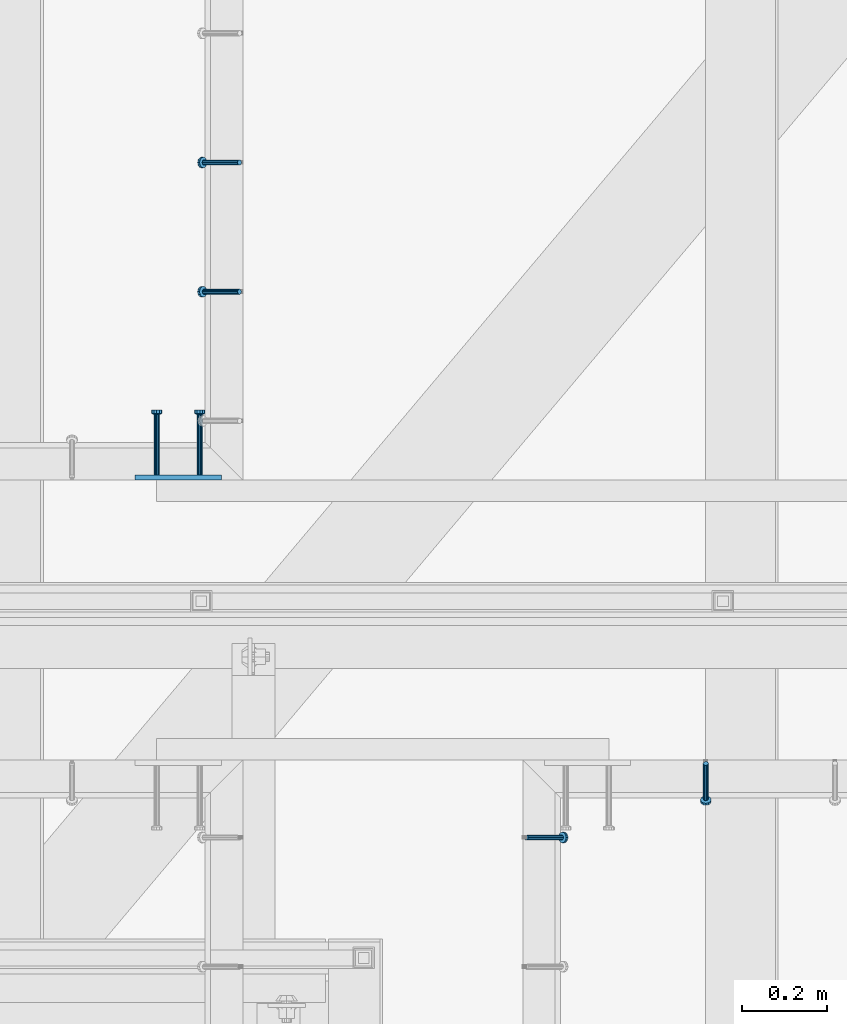
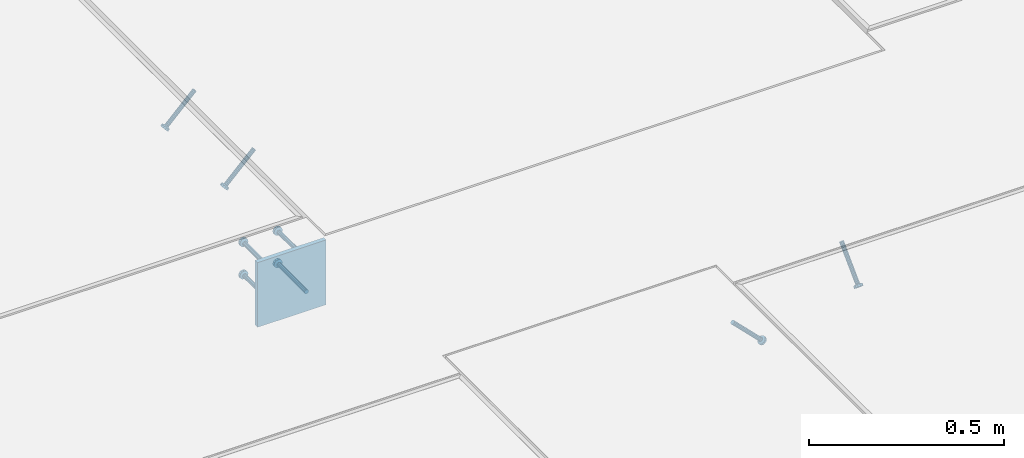
# One storey, part 2122 of 3843: 5 beams, 4 members, 4 elements without a shape of their own.
"""IFC2X3 building model written with IfcOpenShell, lengths in millimetres."""

from ifc_helpers import new_model, si_unit, frame, origin_with_axes, place, context, subcontext, project, spatial, faceted_brep, material, type_object, element, aggregate, save


model = new_model("IFC2X3")

# Units and contexts
model_context = context("Model", 3, precision=1e-05, world=origin_with_axes())
body_context = subcontext(model_context, "Body", "Model", "MODEL_VIEW")
ifc_project = project(units=[si_unit("LENGTHUNIT", "METRE", prefix="MILLI"), si_unit("AREAUNIT", "SQUARE_METRE"), si_unit("VOLUMEUNIT", "CUBIC_METRE"), si_unit("MASSUNIT", "GRAM", prefix="KILO"), si_unit("TIMEUNIT", "SECOND"), si_unit("PLANEANGLEUNIT", "RADIAN"), si_unit("SOLIDANGLEUNIT", "STERADIAN"), si_unit("THERMODYNAMICTEMPERATUREUNIT", "DEGREE_CELSIUS"), si_unit("LUMINOUSINTENSITYUNIT", "LUMEN")], contexts=[model_context])

# Site, building, storey
site_placement = place(None, origin_with_axes())
site = spatial("IfcSite", under=ifc_project, at=site_placement, CompositionType="ELEMENT")
building_placement = place(site_placement, origin_with_axes())
building = spatial("IfcBuilding", under=site, at=building_placement, Name="Undefined", CompositionType="ELEMENT")
storey_placement = place(building_placement, origin_with_axes())
storey = spatial("IfcBuildingStorey", under=building, at=storey_placement, Name="Undefined", CompositionType="ELEMENT", Elevation=0.0)

# Assembly, member
assembly_1_placement = place(storey_placement, origin_with_axes())
assembly_1 = element("IfcElementAssembly", 1, at=assembly_1_placement, inside=storey, Name="EMBED_ANGLE", AssemblyPlace="NOTDEFINED", PredefinedType="RIGID_FRAME")
ifc_material_1 = material(Name="STEEL/A108")
member_type = type_object("IfcMemberType", PredefinedType="NOTDEFINED")
member_1_placement = place(assembly_1_placement, frame((51951.6995146959, 27986.0374966989, 30446.6625), z_axis=(0.0, 1.0, 0.0), x_axis=(0.707106781186548, 0.0, -0.707106781186548)))
member_1 = element("IfcMember", 2, at=member_1_placement, type_object=member_type, material=ifc_material_1, Name="HEADED STUD ANCHOR", context=body_context, shape_type="Brep", body=[
    faceted_brep([(7.27595761418343e-12, -3.18000006675175, 5.5), (0.0, -5.49999999998363, 3.1800000667572), (118.110000000976, -5.49999999999091, 3.1800000667572), (118.110000000983, -3.18000006675175, 5.5), (0.0, -6.3499999046162, 0.0), (118.110000000968, -6.34999990461256, 0.0), (0.0, -5.49999999998363, -3.1800000667572), (118.110000000976, -5.49999999999091, -3.1800000667572), (7.27595761418343e-12, -3.18000006675175, -5.5), (118.110000000983, -3.18000006675175, -5.5), (7.27595761418343e-12, -1.81898940354586e-12, -6.34999990463257), (118.110000000968, -1.81898940354586e-12, -6.34999990463257), (0.0, 3.18000006675175, -5.5), (118.110000000968, 3.18000006674811, -5.5), (7.27595761418343e-12, 5.49999999998363, -3.1800000667572), (118.110000000983, 5.49999999998363, -3.1800000667572), (7.27595761418343e-12, 6.3499999046162, 0.0), (118.110000000976, 6.34999990461256, 0.0), (7.27595761418343e-12, 5.49999999998363, 3.1800000667572), (118.110000000983, 5.49999999998363, 3.1800000667572), (0.0, 3.18000006675175, 5.5), (118.110000000968, 3.18000006674811, 5.5), (7.27595761418343e-12, -1.81898940354586e-12, 6.34999990463257), (118.110000000968, -1.81898940354586e-12, 6.34999990463257), (120.650000000991, -10.9899997710909, 6.34999990463257), (120.650000000998, -6.34000015257152, 10.9899997711182), (120.650000000991, -12.6999998092379, 0.0), (120.650000000991, -10.9899997710909, -6.34999990463257), (120.650000000998, -6.34000015257152, -10.9899997711182), (120.650000000991, -1.81898940354586e-12, -12.6899995803833), (120.650000000991, 6.34000015257152, -10.9899997711182), (120.650000000998, 10.9899997710909, -6.34999990463257), (120.650000000991, 12.6999998092342, 0.0), (120.650000000998, 10.9899997710909, 6.34999990463257), (120.650000000991, 6.34000015257152, 10.9899997711182), (120.650000000991, -1.81898940354586e-12, 12.6899995803833), (127.000000001048, -10.9899997710945, 6.34999990463257), (127.000000001048, -6.34000015257152, 10.9899997711182), (127.000000001048, -12.6999998092342, 0.0), (127.000000001048, -10.9899997710945, -6.34999990463257), (127.000000001048, -6.34000015257152, -10.9899997711182), (127.000000001048, 1.81898940354586e-12, -12.6899995803833), (127.000000001048, 6.34000015256788, -10.9899997711182), (127.000000001048, 10.9899997710909, -6.34999990463257), (127.000000001048, 12.6999998092379, 0.0), (127.000000001048, 10.9899997710909, 6.34999990463257), (127.000000001048, 6.34000015256788, 10.9899997711182), (127.000000001048, 1.81898940354586e-12, 12.6899995803833)], [[[0, 1, 2, 3]], [[1, 4, 5, 2]], [[4, 6, 7, 5]], [[6, 8, 9, 7]], [[8, 10, 11, 9]], [[10, 12, 13, 11]], [[12, 14, 15, 13]], [[14, 16, 17, 15]], [[16, 18, 19, 17]], [[18, 20, 21, 19]], [[20, 22, 23, 21]], [[22, 0, 3, 23]], [[22, 20, 18, 16, 14, 12, 10, 8, 6, 4, 1, 0]], [[3, 2, 24, 25]], [[2, 5, 26, 24]], [[5, 7, 27, 26]], [[7, 9, 28, 27]], [[9, 11, 29, 28]], [[11, 13, 30, 29]], [[13, 15, 31, 30]], [[15, 17, 32, 31]], [[17, 19, 33, 32]], [[19, 21, 34, 33]], [[21, 23, 35, 34]], [[23, 3, 25, 35]], [[25, 24, 36, 37]], [[24, 26, 38, 36]], [[26, 27, 39, 38]], [[27, 28, 40, 39]], [[28, 29, 41, 40]], [[29, 30, 42, 41]], [[30, 31, 43, 42]], [[31, 32, 44, 43]], [[32, 33, 45, 44]], [[33, 34, 46, 45]], [[34, 35, 47, 46]], [[35, 25, 37, 47]], [[38, 39, 40, 41, 42, 43, 44, 45, 46, 47, 37, 36]]]),
])
aggregate(assembly_1, [member_1])

assembly_2_placement = place(storey_placement, origin_with_axes())
assembly_2 = element("IfcElementAssembly", 3, at=assembly_2_placement, inside=storey, Name="EMBED_ANGLE", AssemblyPlace="NOTDEFINED", PredefinedType="RIGID_FRAME")
member_2_placement = place(assembly_2_placement, frame((52375.5623417968, 28160.6624984764, 30446.6625), z_axis=(-1.0, 0.0, 0.0), x_axis=(0.0, -0.707106781186548, -0.707106781186548)))
member_2 = element("IfcMember", 4, at=member_2_placement, type_object=member_type, material=ifc_material_1, Name="HEADED STUD ANCHOR", context=body_context, shape_type="Brep", body=[
    faceted_brep([(7.27595761418343e-12, -3.18000006675175, 5.5), (0.0, -5.49999999998363, 3.1800000667572), (118.110000000976, -5.49999999999091, 3.1800000667572), (118.110000000983, -3.18000006675175, 5.5), (0.0, -6.3499999046162, 0.0), (118.110000000968, -6.34999990461256, 0.0), (0.0, -5.49999999998363, -3.1800000667572), (118.110000000976, -5.49999999999091, -3.1800000667572), (7.27595761418343e-12, -3.18000006675175, -5.5), (118.110000000983, -3.18000006675175, -5.5), (7.27595761418343e-12, -1.81898940354586e-12, -6.34999990463257), (118.110000000968, -1.81898940354586e-12, -6.34999990463257), (0.0, 3.18000006675175, -5.5), (118.110000000968, 3.18000006674811, -5.5), (7.27595761418343e-12, 5.49999999998363, -3.1800000667572), (118.110000000983, 5.49999999998363, -3.1800000667572), (7.27595761418343e-12, 6.3499999046162, 0.0), (118.110000000976, 6.34999990461256, 0.0), (7.27595761418343e-12, 5.49999999998363, 3.1800000667572), (118.110000000983, 5.49999999998363, 3.1800000667572), (0.0, 3.18000006675175, 5.5), (118.110000000968, 3.18000006674811, 5.5), (7.27595761418343e-12, -1.81898940354586e-12, 6.34999990463257), (118.110000000968, -1.81898940354586e-12, 6.34999990463257), (120.650000000991, -10.9899997710909, 6.34999990463257), (120.650000000998, -6.34000015257152, 10.9899997711182), (120.650000000991, -12.6999998092379, 0.0), (120.650000000991, -10.9899997710909, -6.34999990463257), (120.650000000998, -6.34000015257152, -10.9899997711182), (120.650000000991, -1.81898940354586e-12, -12.6899995803833), (120.650000000991, 6.34000015257152, -10.9899997711182), (120.650000000998, 10.9899997710909, -6.34999990463257), (120.650000000991, 12.6999998092342, 0.0), (120.650000000998, 10.9899997710909, 6.34999990463257), (120.650000000991, 6.34000015257152, 10.9899997711182), (120.650000000991, -1.81898940354586e-12, 12.6899995803833), (127.000000001048, -10.9899997710945, 6.34999990463257), (127.000000001048, -6.34000015257152, 10.9899997711182), (127.000000001048, -12.6999998092342, 0.0), (127.000000001048, -10.9899997710945, -6.34999990463257), (127.000000001048, -6.34000015257152, -10.9899997711182), (127.000000001048, 1.81898940354586e-12, -12.6899995803833), (127.000000001048, 6.34000015256788, -10.9899997711182), (127.000000001048, 10.9899997710909, -6.34999990463257), (127.000000001048, 12.6999998092379, 0.0), (127.000000001048, 10.9899997710909, 6.34999990463257), (127.000000001048, 6.34000015256788, 10.9899997711182), (127.000000001048, 1.81898940354586e-12, 12.6899995803833)], [[[0, 1, 2, 3]], [[1, 4, 5, 2]], [[4, 6, 7, 5]], [[6, 8, 9, 7]], [[8, 10, 11, 9]], [[10, 12, 13, 11]], [[12, 14, 15, 13]], [[14, 16, 17, 15]], [[16, 18, 19, 17]], [[18, 20, 21, 19]], [[20, 22, 23, 21]], [[22, 0, 3, 23]], [[22, 20, 18, 16, 14, 12, 10, 8, 6, 4, 1, 0]], [[3, 2, 24, 25]], [[2, 5, 26, 24]], [[5, 7, 27, 26]], [[7, 9, 28, 27]], [[9, 11, 29, 28]], [[11, 13, 30, 29]], [[13, 15, 31, 30]], [[15, 17, 32, 31]], [[17, 19, 33, 32]], [[19, 21, 34, 33]], [[21, 23, 35, 34]], [[23, 3, 25, 35]], [[25, 24, 36, 37]], [[24, 26, 38, 36]], [[26, 27, 39, 38]], [[27, 28, 40, 39]], [[28, 29, 41, 40]], [[29, 30, 42, 41]], [[30, 31, 43, 42]], [[31, 32, 44, 43]], [[32, 33, 45, 44]], [[33, 34, 46, 45]], [[34, 35, 47, 46]], [[35, 25, 37, 47]], [[38, 39, 40, 41, 42, 43, 44, 45, 46, 47, 37, 36]]]),
])
aggregate(assembly_2, [member_2])

# Assembly, members
assembly_3_placement = place(storey_placement, origin_with_axes())
assembly_3 = element("IfcElementAssembly", 5, at=assembly_3_placement, inside=storey, Name="EMBED_ANGLE", AssemblyPlace="NOTDEFINED", PredefinedType="RIGID_FRAME")
member_3_placement = place(assembly_3_placement, frame((51275.424484375, 29273.626609375, 30446.6625), z_axis=(0.0, 1.0, 0.0), x_axis=(-0.707106781186548, 0.0, -0.707106781186548)))
member_3 = element("IfcMember", 6, at=member_3_placement, type_object=member_type, material=ifc_material_1, Name="HEADED STUD ANCHOR", context=body_context, shape_type="Brep", body=[
    faceted_brep([(7.27595761418343e-12, -3.18000006675175, 5.5), (0.0, -5.49999999998363, 3.1800000667572), (118.110000000976, -5.49999999999091, 3.1800000667572), (118.110000000983, -3.18000006675175, 5.5), (0.0, -6.3499999046162, 0.0), (118.110000000968, -6.34999990461256, 0.0), (0.0, -5.49999999998363, -3.1800000667572), (118.110000000976, -5.49999999999091, -3.1800000667572), (7.27595761418343e-12, -3.18000006675175, -5.5), (118.110000000983, -3.18000006675175, -5.5), (7.27595761418343e-12, -1.81898940354586e-12, -6.34999990463257), (118.110000000968, -1.81898940354586e-12, -6.34999990463257), (0.0, 3.18000006675175, -5.5), (118.110000000968, 3.18000006674811, -5.5), (7.27595761418343e-12, 5.49999999998363, -3.1800000667572), (118.110000000983, 5.49999999998363, -3.1800000667572), (7.27595761418343e-12, 6.3499999046162, 0.0), (118.110000000976, 6.34999990461256, 0.0), (7.27595761418343e-12, 5.49999999998363, 3.1800000667572), (118.110000000983, 5.49999999998363, 3.1800000667572), (0.0, 3.18000006675175, 5.5), (118.110000000968, 3.18000006674811, 5.5), (7.27595761418343e-12, -1.81898940354586e-12, 6.34999990463257), (118.110000000968, -1.81898940354586e-12, 6.34999990463257), (120.650000000991, -10.9899997710909, 6.34999990463257), (120.650000000998, -6.34000015257152, 10.9899997711182), (120.650000000991, -12.6999998092379, 0.0), (120.650000000991, -10.9899997710909, -6.34999990463257), (120.650000000998, -6.34000015257152, -10.9899997711182), (120.650000000991, -1.81898940354586e-12, -12.6899995803833), (120.650000000991, 6.34000015257152, -10.9899997711182), (120.650000000998, 10.9899997710909, -6.34999990463257), (120.650000000991, 12.6999998092342, 0.0), (120.650000000998, 10.9899997710909, 6.34999990463257), (120.650000000991, 6.34000015257152, 10.9899997711182), (120.650000000991, -1.81898940354586e-12, 12.6899995803833), (127.000000001048, -10.9899997710945, 6.34999990463257), (127.000000001048, -6.34000015257152, 10.9899997711182), (127.000000001048, -12.6999998092342, 0.0), (127.000000001048, -10.9899997710945, -6.34999990463257), (127.000000001048, -6.34000015257152, -10.9899997711182), (127.000000001048, 1.81898940354586e-12, -12.6899995803833), (127.000000001048, 6.34000015256788, -10.9899997711182), (127.000000001048, 10.9899997710909, -6.34999990463257), (127.000000001048, 12.6999998092379, 0.0), (127.000000001048, 10.9899997710909, 6.34999990463257), (127.000000001048, 6.34000015256788, 10.9899997711182), (127.000000001048, 1.81898940354586e-12, 12.6899995803833)], [[[0, 1, 2, 3]], [[1, 4, 5, 2]], [[4, 6, 7, 5]], [[6, 8, 9, 7]], [[8, 10, 11, 9]], [[10, 12, 13, 11]], [[12, 14, 15, 13]], [[14, 16, 17, 15]], [[16, 18, 19, 17]], [[18, 20, 21, 19]], [[20, 22, 23, 21]], [[22, 0, 3, 23]], [[22, 20, 18, 16, 14, 12, 10, 8, 6, 4, 1, 0]], [[3, 2, 24, 25]], [[2, 5, 26, 24]], [[5, 7, 27, 26]], [[7, 9, 28, 27]], [[9, 11, 29, 28]], [[11, 13, 30, 29]], [[13, 15, 31, 30]], [[15, 17, 32, 31]], [[17, 19, 33, 32]], [[19, 21, 34, 33]], [[21, 23, 35, 34]], [[23, 3, 25, 35]], [[25, 24, 36, 37]], [[24, 26, 38, 36]], [[26, 27, 39, 38]], [[27, 28, 40, 39]], [[28, 29, 41, 40]], [[29, 30, 42, 41]], [[30, 31, 43, 42]], [[31, 32, 44, 43]], [[32, 33, 45, 44]], [[33, 34, 46, 45]], [[34, 35, 47, 46]], [[35, 25, 37, 47]], [[38, 39, 40, 41, 42, 43, 44, 45, 46, 47, 37, 36]]]),
])
member_4_placement = place(assembly_3_placement, frame((51275.424484375, 29578.426609375, 30446.6625), z_axis=(0.0, 1.0, 0.0), x_axis=(-0.707106781186548, 0.0, -0.707106781186548)))
member_4 = element("IfcMember", 7, at=member_4_placement, type_object=member_type, material=ifc_material_1, Name="HEADED STUD ANCHOR", context=body_context, shape_type="Brep", body=[
    faceted_brep([(7.27595761418343e-12, -3.18000006675175, 5.5), (0.0, -5.49999999998363, 3.1800000667572), (118.110000000976, -5.49999999999091, 3.1800000667572), (118.110000000983, -3.18000006675175, 5.5), (0.0, -6.3499999046162, 0.0), (118.110000000968, -6.34999990461256, 0.0), (0.0, -5.49999999998363, -3.1800000667572), (118.110000000976, -5.49999999999091, -3.1800000667572), (7.27595761418343e-12, -3.18000006675175, -5.5), (118.110000000983, -3.18000006675175, -5.5), (7.27595761418343e-12, -1.81898940354586e-12, -6.34999990463257), (118.110000000968, -1.81898940354586e-12, -6.34999990463257), (0.0, 3.18000006675175, -5.5), (118.110000000968, 3.18000006674811, -5.5), (7.27595761418343e-12, 5.49999999998363, -3.1800000667572), (118.110000000983, 5.49999999998363, -3.1800000667572), (7.27595761418343e-12, 6.3499999046162, 0.0), (118.110000000976, 6.34999990461256, 0.0), (7.27595761418343e-12, 5.49999999998363, 3.1800000667572), (118.110000000983, 5.49999999998363, 3.1800000667572), (0.0, 3.18000006675175, 5.5), (118.110000000968, 3.18000006674811, 5.5), (7.27595761418343e-12, -1.81898940354586e-12, 6.34999990463257), (118.110000000968, -1.81898940354586e-12, 6.34999990463257), (120.650000000991, -10.9899997710909, 6.34999990463257), (120.650000000998, -6.34000015257152, 10.9899997711182), (120.650000000991, -12.6999998092379, 0.0), (120.650000000991, -10.9899997710909, -6.34999990463257), (120.650000000998, -6.34000015257152, -10.9899997711182), (120.650000000991, -1.81898940354586e-12, -12.6899995803833), (120.650000000991, 6.34000015257152, -10.9899997711182), (120.650000000998, 10.9899997710909, -6.34999990463257), (120.650000000991, 12.6999998092342, 0.0), (120.650000000998, 10.9899997710909, 6.34999990463257), (120.650000000991, 6.34000015257152, 10.9899997711182), (120.650000000991, -1.81898940354586e-12, 12.6899995803833), (127.000000001048, -10.9899997710945, 6.34999990463257), (127.000000001048, -6.34000015257152, 10.9899997711182), (127.000000001048, -12.6999998092342, 0.0), (127.000000001048, -10.9899997710945, -6.34999990463257), (127.000000001048, -6.34000015257152, -10.9899997711182), (127.000000001048, 1.81898940354586e-12, -12.6899995803833), (127.000000001048, 6.34000015256788, -10.9899997711182), (127.000000001048, 10.9899997710909, -6.34999990463257), (127.000000001048, 12.6999998092379, 0.0), (127.000000001048, 10.9899997710909, 6.34999990463257), (127.000000001048, 6.34000015256788, 10.9899997711182), (127.000000001048, 1.81898940354586e-12, 12.6899995803833)], [[[0, 1, 2, 3]], [[1, 4, 5, 2]], [[4, 6, 7, 5]], [[6, 8, 9, 7]], [[8, 10, 11, 9]], [[10, 12, 13, 11]], [[12, 14, 15, 13]], [[14, 16, 17, 15]], [[16, 18, 19, 17]], [[18, 20, 21, 19]], [[20, 22, 23, 21]], [[22, 0, 3, 23]], [[22, 20, 18, 16, 14, 12, 10, 8, 6, 4, 1, 0]], [[3, 2, 24, 25]], [[2, 5, 26, 24]], [[5, 7, 27, 26]], [[7, 9, 28, 27]], [[9, 11, 29, 28]], [[11, 13, 30, 29]], [[13, 15, 31, 30]], [[15, 17, 32, 31]], [[17, 19, 33, 32]], [[19, 21, 34, 33]], [[21, 23, 35, 34]], [[23, 3, 25, 35]], [[25, 24, 36, 37]], [[24, 26, 38, 36]], [[26, 27, 39, 38]], [[27, 28, 40, 39]], [[28, 29, 41, 40]], [[29, 30, 42, 41]], [[30, 31, 43, 42]], [[31, 32, 44, 43]], [[32, 33, 45, 44]], [[33, 34, 46, 45]], [[34, 35, 47, 46]], [[35, 25, 37, 47]], [[38, 39, 40, 41, 42, 43, 44, 45, 46, 47, 37, 36]]]),
])
aggregate(assembly_3, [member_3, member_4])

# Assembly, beams
assembly_4_placement = place(storey_placement, origin_with_axes())
assembly_4 = element("IfcElementAssembly", 8, at=assembly_4_placement, inside=storey, Name="EMBED PLATE", AssemblyPlace="NOTDEFINED", PredefinedType="RIGID_FRAME")
ifc_material_2 = material(Name="STEEL/A36")
beam_type_1 = type_object("IfcBeamType", PredefinedType="NOTDEFINED")
beam_1_placement = place(assembly_4_placement, frame((51130.961984375, 28835.35, 30445.075), z_axis=(1.0, 0.0, 0.0), x_axis=(0.0, 0.0, -1.0)))
beam_1 = element("IfcBeam", 9, at=beam_1_placement, type_object=beam_type_1, material=ifc_material_2, Name="EMBED PLATE", context=body_context, shape_type="Brep", body=[
    faceted_brep([(1.74622982740402e-10, 6.35000000000582, -101.600000000195), (-1.67347025126219e-10, 6.35000000000582, 101.600000000151), (203.200000000001, 6.35000000000582, 101.599999999999), (203.200000000001, 6.35000000000582, -101.599999999999), (-1.67347025126219e-10, -6.35000000000582, 101.600000000151), (203.200000000001, -6.35000000000582, 101.599999999999), (1.74622982740402e-10, -6.35000000000582, -101.600000000195), (203.200000000001, -6.35000000000582, -101.599999999999)], [[[0, 1, 2, 3]], [[1, 4, 5, 2]], [[4, 6, 7, 5]], [[6, 0, 3, 7]], [[5, 7, 3, 2]], [[6, 4, 1, 0]]]),
])
beam_type_2 = type_object("IfcBeamType", PredefinedType="NOTDEFINED")
beam_2_placement = place(assembly_4_placement, frame((51080.161984375, 28841.7, 30394.275), z_axis=(-1.0, 0.0, 0.0), x_axis=(0.0, 1.0, 0.0)))
beam_2 = element("IfcBeam", 10, at=beam_2_placement, type_object=beam_type_2, material=ifc_material_1, Name="HEADED STUD ANCHOR", context=body_context, shape_type="Brep", body=[
    faceted_brep([(7.27595761418343e-12, -3.18000006675175, 5.5), (0.0, -5.49999999998363, 3.1800000667572), (141.731999999989, -5.5, 3.1800000667572), (141.731999999989, -3.1800000667572, 5.5), (0.0, -6.3499999046162, 0.0), (141.731999999989, -6.34999990463257, 0.0), (0.0, -5.49999999998363, -3.1800000667572), (141.731999999989, -5.5, -3.1800000667572), (7.27595761418343e-12, -3.18000006675175, -5.5), (141.731999999989, -3.1800000667572, -5.5), (7.27595761418343e-12, -1.81898940354586e-12, -6.34999990463257), (141.731999999989, 0.0, -6.34999990463257), (0.0, 3.18000006675175, -5.5), (141.731999999989, 3.1800000667572, -5.5), (7.27595761418343e-12, 5.49999999998363, -3.1800000667572), (141.731999999989, 5.5, -3.1800000667572), (7.27595761418343e-12, 6.3499999046162, 0.0), (141.731999999989, 6.34999990463257, 0.0), (7.27595761418343e-12, 5.49999999998363, 3.1800000667572), (141.731999999989, 5.5, 3.1800000667572), (0.0, 3.18000006675175, 5.5), (141.731999999989, 3.1800000667572, 5.5), (7.27595761418343e-12, -1.81898940354586e-12, 6.34999990463257), (141.731999999989, 0.0, 6.34999990463257), (144.779999999999, -10.9899997711182, 6.34999990463257), (144.779999999999, -6.34000015258789, 10.9899997711182), (144.779999999999, -12.6999998092651, 0.0), (144.779999999999, -10.9899997711182, -6.34999990463257), (144.779999999999, -6.34000015258789, -10.9899997711182), (144.779999999999, 0.0, -12.6899995803833), (144.779999999999, 6.34000015258789, -10.9899997711182), (144.779999999999, 10.9899997711182, -6.34999990463257), (144.779999999999, 12.6999998092651, 0.0), (144.779999999999, 10.9899997711182, 6.34999990463257), (144.779999999999, 6.34000015258789, 10.9899997711182), (144.779999999999, 0.0, 12.6899995803833), (152.399999999994, -10.9899997711182, 6.34999990463257), (152.399999999994, -6.34000015258789, 10.9899997711182), (152.399999999994, -12.6999998092651, 0.0), (152.399999999994, -10.9899997711182, -6.34999990463257), (152.399999999994, -6.34000015258789, -10.9899997711182), (152.399999999994, 0.0, -12.6899995803833), (152.399999999994, 6.34000015258789, -10.9899997711182), (152.399999999994, 10.9899997711182, -6.34999990463257), (152.399999999994, 12.6999998092651, 0.0), (152.399999999994, 10.9899997711182, 6.34999990463257), (152.399999999994, 6.34000015258789, 10.9899997711182), (152.399999999994, 0.0, 12.6899995803833)], [[[0, 1, 2, 3]], [[1, 4, 5, 2]], [[4, 6, 7, 5]], [[6, 8, 9, 7]], [[8, 10, 11, 9]], [[10, 12, 13, 11]], [[12, 14, 15, 13]], [[14, 16, 17, 15]], [[16, 18, 19, 17]], [[18, 20, 21, 19]], [[20, 22, 23, 21]], [[22, 0, 3, 23]], [[22, 20, 18, 16, 14, 12, 10, 8, 6, 4, 1, 0]], [[3, 2, 24, 25]], [[2, 5, 26, 24]], [[5, 7, 27, 26]], [[7, 9, 28, 27]], [[9, 11, 29, 28]], [[11, 13, 30, 29]], [[13, 15, 31, 30]], [[15, 17, 32, 31]], [[17, 19, 33, 32]], [[19, 21, 34, 33]], [[21, 23, 35, 34]], [[23, 3, 25, 35]], [[25, 24, 36, 37]], [[24, 26, 38, 36]], [[26, 27, 39, 38]], [[27, 28, 40, 39]], [[28, 29, 41, 40]], [[29, 30, 42, 41]], [[30, 31, 43, 42]], [[31, 32, 44, 43]], [[32, 33, 45, 44]], [[33, 34, 46, 45]], [[34, 35, 47, 46]], [[35, 25, 37, 47]], [[38, 39, 40, 41, 42, 43, 44, 45, 46, 47, 37, 36]]]),
])
beam_3_placement = place(assembly_4_placement, frame((51080.161984375, 28841.7, 30292.675), z_axis=(-1.0, 0.0, 0.0), x_axis=(0.0, 1.0, 0.0)))
beam_3 = element("IfcBeam", 11, at=beam_3_placement, type_object=beam_type_2, material=ifc_material_1, Name="HEADED STUD ANCHOR", context=body_context, shape_type="Brep", body=[
    faceted_brep([(7.27595761418343e-12, -3.18000006675175, 5.5), (0.0, -5.49999999998363, 3.1800000667572), (141.731999999989, -5.5, 3.1800000667572), (141.731999999989, -3.1800000667572, 5.5), (0.0, -6.3499999046162, 0.0), (141.731999999989, -6.34999990463257, 0.0), (0.0, -5.49999999998363, -3.1800000667572), (141.731999999989, -5.5, -3.1800000667572), (7.27595761418343e-12, -3.18000006675175, -5.5), (141.731999999989, -3.1800000667572, -5.5), (7.27595761418343e-12, -1.81898940354586e-12, -6.34999990463257), (141.731999999989, 0.0, -6.34999990463257), (0.0, 3.18000006675175, -5.5), (141.731999999989, 3.1800000667572, -5.5), (7.27595761418343e-12, 5.49999999998363, -3.1800000667572), (141.731999999989, 5.5, -3.1800000667572), (7.27595761418343e-12, 6.3499999046162, 0.0), (141.731999999989, 6.34999990463257, 0.0), (7.27595761418343e-12, 5.49999999998363, 3.1800000667572), (141.731999999989, 5.5, 3.1800000667572), (0.0, 3.18000006675175, 5.5), (141.731999999989, 3.1800000667572, 5.5), (7.27595761418343e-12, -1.81898940354586e-12, 6.34999990463257), (141.731999999989, 0.0, 6.34999990463257), (144.779999999999, -10.9899997711182, 6.34999990463257), (144.779999999999, -6.34000015258789, 10.9899997711182), (144.779999999999, -12.6999998092651, 0.0), (144.779999999999, -10.9899997711182, -6.34999990463257), (144.779999999999, -6.34000015258789, -10.9899997711182), (144.779999999999, 0.0, -12.6899995803833), (144.779999999999, 6.34000015258789, -10.9899997711182), (144.779999999999, 10.9899997711182, -6.34999990463257), (144.779999999999, 12.6999998092651, 0.0), (144.779999999999, 10.9899997711182, 6.34999990463257), (144.779999999999, 6.34000015258789, 10.9899997711182), (144.779999999999, 0.0, 12.6899995803833), (152.399999999994, -10.9899997711182, 6.34999990463257), (152.399999999994, -6.34000015258789, 10.9899997711182), (152.399999999994, -12.6999998092651, 0.0), (152.399999999994, -10.9899997711182, -6.34999990463257), (152.399999999994, -6.34000015258789, -10.9899997711182), (152.399999999994, 0.0, -12.6899995803833), (152.399999999994, 6.34000015258789, -10.9899997711182), (152.399999999994, 10.9899997711182, -6.34999990463257), (152.399999999994, 12.6999998092651, 0.0), (152.399999999994, 10.9899997711182, 6.34999990463257), (152.399999999994, 6.34000015258789, 10.9899997711182), (152.399999999994, 0.0, 12.6899995803833)], [[[0, 1, 2, 3]], [[1, 4, 5, 2]], [[4, 6, 7, 5]], [[6, 8, 9, 7]], [[8, 10, 11, 9]], [[10, 12, 13, 11]], [[12, 14, 15, 13]], [[14, 16, 17, 15]], [[16, 18, 19, 17]], [[18, 20, 21, 19]], [[20, 22, 23, 21]], [[22, 0, 3, 23]], [[22, 20, 18, 16, 14, 12, 10, 8, 6, 4, 1, 0]], [[3, 2, 24, 25]], [[2, 5, 26, 24]], [[5, 7, 27, 26]], [[7, 9, 28, 27]], [[9, 11, 29, 28]], [[11, 13, 30, 29]], [[13, 15, 31, 30]], [[15, 17, 32, 31]], [[17, 19, 33, 32]], [[19, 21, 34, 33]], [[21, 23, 35, 34]], [[23, 3, 25, 35]], [[25, 24, 36, 37]], [[24, 26, 38, 36]], [[26, 27, 39, 38]], [[27, 28, 40, 39]], [[28, 29, 41, 40]], [[29, 30, 42, 41]], [[30, 31, 43, 42]], [[31, 32, 44, 43]], [[32, 33, 45, 44]], [[33, 34, 46, 45]], [[34, 35, 47, 46]], [[35, 25, 37, 47]], [[38, 39, 40, 41, 42, 43, 44, 45, 46, 47, 37, 36]]]),
])
beam_4_placement = place(assembly_4_placement, frame((51181.761984375, 28841.7, 30394.275), z_axis=(-1.0, 0.0, 0.0), x_axis=(0.0, 1.0, 0.0)))
beam_4 = element("IfcBeam", 12, at=beam_4_placement, type_object=beam_type_2, material=ifc_material_1, Name="HEADED STUD ANCHOR", context=body_context, shape_type="Brep", body=[
    faceted_brep([(7.27595761418343e-12, -3.18000006675175, 5.5), (0.0, -5.49999999998363, 3.1800000667572), (141.731999999989, -5.5, 3.1800000667572), (141.731999999989, -3.1800000667572, 5.5), (0.0, -6.3499999046162, 0.0), (141.731999999989, -6.34999990463257, 0.0), (0.0, -5.49999999998363, -3.1800000667572), (141.731999999989, -5.5, -3.1800000667572), (7.27595761418343e-12, -3.18000006675175, -5.5), (141.731999999989, -3.1800000667572, -5.5), (7.27595761418343e-12, -1.81898940354586e-12, -6.34999990463257), (141.731999999989, 0.0, -6.34999990463257), (0.0, 3.18000006675175, -5.5), (141.731999999989, 3.1800000667572, -5.5), (7.27595761418343e-12, 5.49999999998363, -3.1800000667572), (141.731999999989, 5.5, -3.1800000667572), (7.27595761418343e-12, 6.3499999046162, 0.0), (141.731999999989, 6.34999990463257, 0.0), (7.27595761418343e-12, 5.49999999998363, 3.1800000667572), (141.731999999989, 5.5, 3.1800000667572), (0.0, 3.18000006675175, 5.5), (141.731999999989, 3.1800000667572, 5.5), (7.27595761418343e-12, -1.81898940354586e-12, 6.34999990463257), (141.731999999989, 0.0, 6.34999990463257), (144.779999999999, -10.9899997711182, 6.34999990463257), (144.779999999999, -6.34000015258789, 10.9899997711182), (144.779999999999, -12.6999998092651, 0.0), (144.779999999999, -10.9899997711182, -6.34999990463257), (144.779999999999, -6.34000015258789, -10.9899997711182), (144.779999999999, 0.0, -12.6899995803833), (144.779999999999, 6.34000015258789, -10.9899997711182), (144.779999999999, 10.9899997711182, -6.34999990463257), (144.779999999999, 12.6999998092651, 0.0), (144.779999999999, 10.9899997711182, 6.34999990463257), (144.779999999999, 6.34000015258789, 10.9899997711182), (144.779999999999, 0.0, 12.6899995803833), (152.399999999994, -10.9899997711182, 6.34999990463257), (152.399999999994, -6.34000015258789, 10.9899997711182), (152.399999999994, -12.6999998092651, 0.0), (152.399999999994, -10.9899997711182, -6.34999990463257), (152.399999999994, -6.34000015258789, -10.9899997711182), (152.399999999994, 0.0, -12.6899995803833), (152.399999999994, 6.34000015258789, -10.9899997711182), (152.399999999994, 10.9899997711182, -6.34999990463257), (152.399999999994, 12.6999998092651, 0.0), (152.399999999994, 10.9899997711182, 6.34999990463257), (152.399999999994, 6.34000015258789, 10.9899997711182), (152.399999999994, 0.0, 12.6899995803833)], [[[0, 1, 2, 3]], [[1, 4, 5, 2]], [[4, 6, 7, 5]], [[6, 8, 9, 7]], [[8, 10, 11, 9]], [[10, 12, 13, 11]], [[12, 14, 15, 13]], [[14, 16, 17, 15]], [[16, 18, 19, 17]], [[18, 20, 21, 19]], [[20, 22, 23, 21]], [[22, 0, 3, 23]], [[22, 20, 18, 16, 14, 12, 10, 8, 6, 4, 1, 0]], [[3, 2, 24, 25]], [[2, 5, 26, 24]], [[5, 7, 27, 26]], [[7, 9, 28, 27]], [[9, 11, 29, 28]], [[11, 13, 30, 29]], [[13, 15, 31, 30]], [[15, 17, 32, 31]], [[17, 19, 33, 32]], [[19, 21, 34, 33]], [[21, 23, 35, 34]], [[23, 3, 25, 35]], [[25, 24, 36, 37]], [[24, 26, 38, 36]], [[26, 27, 39, 38]], [[27, 28, 40, 39]], [[28, 29, 41, 40]], [[29, 30, 42, 41]], [[30, 31, 43, 42]], [[31, 32, 44, 43]], [[32, 33, 45, 44]], [[33, 34, 46, 45]], [[34, 35, 47, 46]], [[35, 25, 37, 47]], [[38, 39, 40, 41, 42, 43, 44, 45, 46, 47, 37, 36]]]),
])
beam_5_placement = place(assembly_4_placement, frame((51181.761984375, 28841.7, 30292.675), z_axis=(-1.0, 0.0, 0.0), x_axis=(0.0, 1.0, 0.0)))
beam_5 = element("IfcBeam", 13, at=beam_5_placement, type_object=beam_type_2, material=ifc_material_1, Name="HEADED STUD ANCHOR", context=body_context, shape_type="Brep", body=[
    faceted_brep([(7.27595761418343e-12, -3.18000006675175, 5.5), (0.0, -5.49999999998363, 3.1800000667572), (141.731999999989, -5.5, 3.1800000667572), (141.731999999989, -3.1800000667572, 5.5), (0.0, -6.3499999046162, 0.0), (141.731999999989, -6.34999990463257, 0.0), (0.0, -5.49999999998363, -3.1800000667572), (141.731999999989, -5.5, -3.1800000667572), (7.27595761418343e-12, -3.18000006675175, -5.5), (141.731999999989, -3.1800000667572, -5.5), (7.27595761418343e-12, -1.81898940354586e-12, -6.34999990463257), (141.731999999989, 0.0, -6.34999990463257), (0.0, 3.18000006675175, -5.5), (141.731999999989, 3.1800000667572, -5.5), (7.27595761418343e-12, 5.49999999998363, -3.1800000667572), (141.731999999989, 5.5, -3.1800000667572), (7.27595761418343e-12, 6.3499999046162, 0.0), (141.731999999989, 6.34999990463257, 0.0), (7.27595761418343e-12, 5.49999999998363, 3.1800000667572), (141.731999999989, 5.5, 3.1800000667572), (0.0, 3.18000006675175, 5.5), (141.731999999989, 3.1800000667572, 5.5), (7.27595761418343e-12, -1.81898940354586e-12, 6.34999990463257), (141.731999999989, 0.0, 6.34999990463257), (144.779999999999, -10.9899997711182, 6.34999990463257), (144.779999999999, -6.34000015258789, 10.9899997711182), (144.779999999999, -12.6999998092651, 0.0), (144.779999999999, -10.9899997711182, -6.34999990463257), (144.779999999999, -6.34000015258789, -10.9899997711182), (144.779999999999, 0.0, -12.6899995803833), (144.779999999999, 6.34000015258789, -10.9899997711182), (144.779999999999, 10.9899997711182, -6.34999990463257), (144.779999999999, 12.6999998092651, 0.0), (144.779999999999, 10.9899997711182, 6.34999990463257), (144.779999999999, 6.34000015258789, 10.9899997711182), (144.779999999999, 0.0, 12.6899995803833), (152.399999999994, -10.9899997711182, 6.34999990463257), (152.399999999994, -6.34000015258789, 10.9899997711182), (152.399999999994, -12.6999998092651, 0.0), (152.399999999994, -10.9899997711182, -6.34999990463257), (152.399999999994, -6.34000015258789, -10.9899997711182), (152.399999999994, 0.0, -12.6899995803833), (152.399999999994, 6.34000015258789, -10.9899997711182), (152.399999999994, 10.9899997711182, -6.34999990463257), (152.399999999994, 12.6999998092651, 0.0), (152.399999999994, 10.9899997711182, 6.34999990463257), (152.399999999994, 6.34000015258789, 10.9899997711182), (152.399999999994, 0.0, 12.6899995803833)], [[[0, 1, 2, 3]], [[1, 4, 5, 2]], [[4, 6, 7, 5]], [[6, 8, 9, 7]], [[8, 10, 11, 9]], [[10, 12, 13, 11]], [[12, 14, 15, 13]], [[14, 16, 17, 15]], [[16, 18, 19, 17]], [[18, 20, 21, 19]], [[20, 22, 23, 21]], [[22, 0, 3, 23]], [[22, 20, 18, 16, 14, 12, 10, 8, 6, 4, 1, 0]], [[3, 2, 24, 25]], [[2, 5, 26, 24]], [[5, 7, 27, 26]], [[7, 9, 28, 27]], [[9, 11, 29, 28]], [[11, 13, 30, 29]], [[13, 15, 31, 30]], [[15, 17, 32, 31]], [[17, 19, 33, 32]], [[19, 21, 34, 33]], [[21, 23, 35, 34]], [[23, 3, 25, 35]], [[25, 24, 36, 37]], [[24, 26, 38, 36]], [[26, 27, 39, 38]], [[27, 28, 40, 39]], [[28, 29, 41, 40]], [[29, 30, 42, 41]], [[30, 31, 43, 42]], [[31, 32, 44, 43]], [[32, 33, 45, 44]], [[33, 34, 46, 45]], [[34, 35, 47, 46]], [[35, 25, 37, 47]], [[38, 39, 40, 41, 42, 43, 44, 45, 46, 47, 37, 36]]]),
])
aggregate(assembly_4, [beam_2, beam_3, beam_4, beam_5, beam_1])

save(model, "model.ifc")
